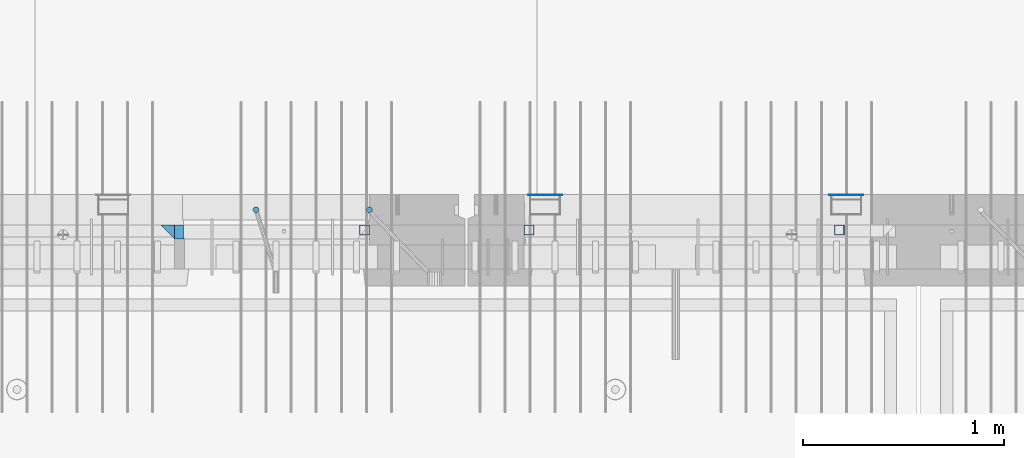
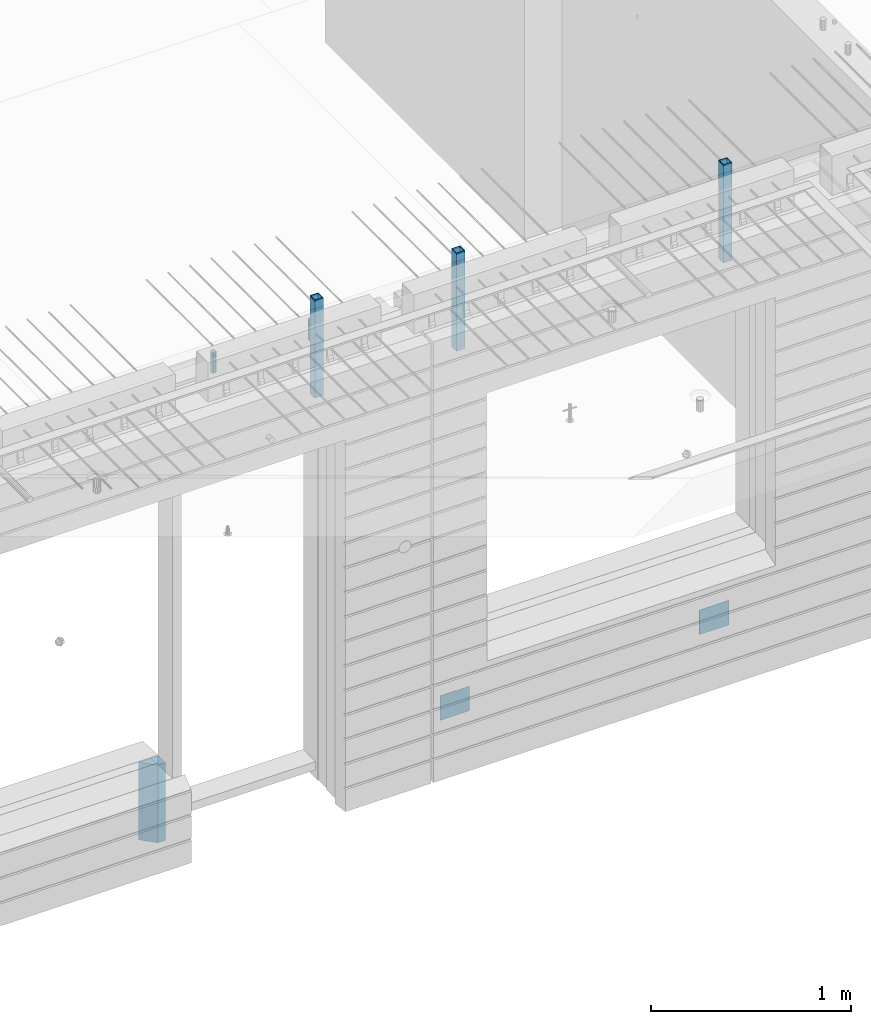
# One storey, part 17 of 350: 9 columns, 7 elements without a shape of their own.
"""IFC2X3 building model written with IfcOpenShell, lengths in millimetres."""

from ifc_helpers import new_model, si_unit, frame, origin_with_axes, place, context, subcontext, project, spatial, faceted_brep, material, type_object, element, aggregate, save


model = new_model("IFC2X3")

# Units and contexts
model_context = context("Model", 3, precision=1e-05, world=origin_with_axes())
body_context = subcontext(model_context, "Body", "Model", "MODEL_VIEW")
ifc_project = project(units=[si_unit("LENGTHUNIT", "METRE", prefix="MILLI"), si_unit("AREAUNIT", "SQUARE_METRE"), si_unit("VOLUMEUNIT", "CUBIC_METRE"), si_unit("MASSUNIT", "GRAM", prefix="KILO"), si_unit("TIMEUNIT", "SECOND"), si_unit("PLANEANGLEUNIT", "RADIAN"), si_unit("SOLIDANGLEUNIT", "STERADIAN"), si_unit("THERMODYNAMICTEMPERATUREUNIT", "DEGREE_CELSIUS"), si_unit("LUMINOUSINTENSITYUNIT", "LUMEN")], contexts=[model_context])

# Site, building, storey
site_placement = place(None, origin_with_axes())
site = spatial("IfcSite", under=ifc_project, at=site_placement, CompositionType="ELEMENT")
building_placement = place(site_placement, origin_with_axes())
building = spatial("IfcBuilding", under=site, at=building_placement, CompositionType="ELEMENT")
storey_placement = place(building_placement, origin_with_axes())
storey = spatial("IfcBuildingStorey", under=building, at=storey_placement, Name="2", CompositionType="ELEMENT", Elevation=0.0)

# Assembly, columns
assembly_1_placement = place(storey_placement, origin_with_axes())
assembly_1 = element("IfcElementAssembly", 1, at=assembly_1_placement, inside=storey, AssemblyPlace="NOTDEFINED", PredefinedType="REINFORCEMENT_UNIT")
ifc_material_1 = material(Name="CONCRETE/C35/45")
column_type_1 = type_object("IfcColumnType", PredefinedType="NOTDEFINED")
column_1_placement = place(assembly_1_placement, frame((24069.9998642727, 7815.0, 84755.0), z_axis=(1.0, 0.0, 0.0), x_axis=(0.0, 0.0, 1.0)))
column_1 = element("IfcColumn", 2, at=column_1_placement, type_object=column_type_1, material=ifc_material_1, Name="SK", context=body_context, shape_type="Brep", body=[
    faceted_brep([(0.0, -35.0, 35.0), (0.0, 35.0, 35.0), (0.0, -35.0, -35.0), (475.0, -35.0, 35.0), (475.0, -35.0, -35.0), (475.0, 35.0, 35.0)], [[[0, 1, 2]], [[3, 0, 2, 4]], [[3, 4, 5]], [[2, 1, 5, 4]], [[0, 3, 5, 1]]]),
])
column_type_2 = type_object("IfcColumnType", PredefinedType="NOTDEFINED")
column_2_placement = place(assembly_1_placement, frame((24129.9998642727, 7815.0, 84755.0), z_axis=(1.0, 0.0, 0.0), x_axis=(0.0, 0.0, 1.0)))
column_2 = element("IfcColumn", 3, at=column_2_placement, type_object=column_type_2, material=ifc_material_1, Name="SK", context=body_context, shape_type="Brep", body=[
    faceted_brep([(0.0, -35.0, -25.0), (0.0, 35.0, -25.0), (475.0, 35.0, -25.0), (475.0, -35.0, -25.0), (0.0, -35.0, 18.8457723764259), (0.0, 35.0, 20.640644171297), (475.0, 35.0, 20.640644171297), (475.0, -35.0, 18.8457723764259)], [[[0, 1, 2, 3]], [[1, 0, 4, 5]], [[2, 1, 5, 6]], [[3, 2, 6, 7]], [[0, 3, 7, 4]], [[6, 5, 4, 7]]]),
])
ifc_material_2 = material()
column_type_3 = type_object("IfcColumnType", Name="D30", PredefinedType="NOTDEFINED")
column_3_placement = place(assembly_1_placement, frame((24510.0000000048, 7924.99999999072, 87407.5), z_axis=(0.0, 1.0, 0.0), x_axis=(0.0, 0.0, 1.0)))
column_3 = element("IfcColumn", 4, at=column_3_placement, type_object=column_type_3, material=ifc_material_2, ObjectType="D30", context=body_context, shape_type="Brep", body=[
    faceted_brep([(0.0, -15.0, 0.0), (0.0, -12.9903810567666, -7.5), (125.0, -12.9903810567666, -7.5), (125.0, -15.0, 0.0), (0.0, -7.5, -12.9903810567666), (125.0, -7.5, -12.9903810567666), (0.0, 0.0, -15.0), (125.0, 0.0, -15.0), (0.0, 7.5, -12.9903810567666), (125.0, 7.5, -12.9903810567666), (0.0, 12.9903810567666, -7.5), (125.0, 12.9903810567666, -7.5), (0.0, 15.0, 0.0), (125.0, 15.0, 0.0), (0.0, 12.9903810567666, 7.5), (125.0, 12.9903810567666, 7.5), (0.0, 7.5, 12.9903810567666), (125.0, 7.5, 12.9903810567666), (0.0, 0.0, 15.0), (125.0, 0.0, 15.0), (0.0, -7.5, 12.9903810567666), (125.0, -7.5, 12.9903810567666), (0.0, -12.9903810567666, 7.5), (125.0, -12.9903810567666, 7.5)], [[[0, 1, 2, 3]], [[1, 4, 5, 2]], [[4, 6, 7, 5]], [[6, 8, 9, 7]], [[8, 10, 11, 9]], [[10, 12, 13, 11]], [[12, 14, 15, 13]], [[14, 16, 17, 15]], [[16, 18, 19, 17]], [[18, 20, 21, 19]], [[20, 22, 23, 21]], [[22, 0, 3, 23]], [[5, 7, 9, 11, 13, 15, 17, 19, 21, 23, 3, 2]], [[22, 20, 18, 16, 14, 12, 10, 8, 6, 4, 1, 0]]]),
])
column_4_placement = place(assembly_1_placement, frame((25074.9926665377, 7925.00000000707, 87407.5), z_axis=(0.0, 1.0, 0.0), x_axis=(0.0, 0.0, 1.0)))
column_4 = element("IfcColumn", 5, at=column_4_placement, type_object=column_type_3, material=ifc_material_2, ObjectType="D30", context=body_context, shape_type="Brep", body=[
    faceted_brep([(0.0, -15.0, 0.0), (0.0, -12.9903810567666, -7.5), (125.0, -12.9903810567666, -7.5), (125.0, -15.0, 0.0), (0.0, -7.5, -12.9903810567666), (125.0, -7.5, -12.9903810567666), (0.0, 0.0, -15.0), (125.0, 0.0, -15.0), (0.0, 7.5, -12.9903810567666), (125.0, 7.5, -12.9903810567666), (0.0, 12.9903810567666, -7.5), (125.0, 12.9903810567666, -7.5), (0.0, 15.0, 0.0), (125.0, 15.0, 0.0), (0.0, 12.9903810567666, 7.5), (125.0, 12.9903810567666, 7.5), (0.0, 7.5, 12.9903810567666), (125.0, 7.5, 12.9903810567666), (0.0, 0.0, 15.0), (125.0, 0.0, 15.0), (0.0, -7.5, 12.9903810567666), (125.0, -7.5, 12.9903810567666), (0.0, -12.9903810567666, 7.5), (125.0, -12.9903810567666, 7.5)], [[[0, 1, 2, 3]], [[1, 4, 5, 2]], [[4, 6, 7, 5]], [[6, 8, 9, 7]], [[8, 10, 11, 9]], [[10, 12, 13, 11]], [[12, 14, 15, 13]], [[14, 16, 17, 15]], [[16, 18, 19, 17]], [[18, 20, 21, 19]], [[20, 22, 23, 21]], [[22, 0, 3, 23]], [[5, 7, 9, 11, 13, 15, 17, 19, 21, 23, 3, 2]], [[22, 20, 18, 16, 14, 12, 10, 8, 6, 4, 1, 0]]]),
])

# Assemblies, columns
assembly_2_placement = place(storey_placement, origin_with_axes())
assembly_2 = element("IfcElementAssembly", 6, at=assembly_2_placement, inside=storey, AssemblyPlace="NOTDEFINED", PredefinedType="REINFORCEMENT_UNIT")
assembly_3_placement = place(assembly_2_placement, origin_with_axes())
assembly_3 = element("IfcElementAssembly", 7, at=assembly_3_placement, Name="Steel Assembly", AssemblyPlace="NOTDEFINED", PredefinedType="NOTDEFINED")
ifc_material_3 = material(Name="Undefined")
column_type_4 = type_object("IfcColumnType", PredefinedType="NOTDEFINED")
column_5_placement = place(assembly_3_placement, frame((25950.0, 7998.99999999844, 84754.9999999985), z_axis=(0.0, 1.0, 0.0), x_axis=(0.0, 0.0, 1.0)))
column_5 = element("IfcColumn", 8, at=column_5_placement, type_object=column_type_4, material=ifc_material_3, Name="SPK2", context=body_context, shape_type="Brep", body=[
    faceted_brep([(0.0, 85.0, -1.0), (0.0, 85.0, 1.0), (150.0, 85.0, 1.0), (150.0, 85.0, -1.0), (0.0, -85.0, 1.0), (150.0, -85.0, 1.0), (0.0, -85.0, -1.0), (150.0, -85.0, -1.0)], [[[0, 1, 2, 3]], [[1, 4, 5, 2]], [[4, 6, 7, 5]], [[6, 0, 3, 7]], [[5, 7, 3, 2]], [[6, 4, 1, 0]]]),
])
aggregate(assembly_3, [column_5])
assembly_4_placement = place(assembly_2_placement, origin_with_axes())
assembly_4 = element("IfcElementAssembly", 9, at=assembly_4_placement, Name="Steel Assembly", AssemblyPlace="NOTDEFINED", PredefinedType="NOTDEFINED")
column_6_placement = place(assembly_4_placement, frame((27450.0, 7998.99999999844, 84754.9999999985), z_axis=(0.0, 1.0, 0.0), x_axis=(0.0, 0.0, 1.0)))
column_6 = element("IfcColumn", 10, at=column_6_placement, type_object=column_type_4, material=ifc_material_3, Name="SPK2", context=body_context, shape_type="Brep", body=[
    faceted_brep([(0.0, 85.0, -1.0), (0.0, 85.0, 1.0), (150.0, 85.0, 1.0), (150.0, 85.0, -1.0), (0.0, -85.0, 1.0), (150.0, -85.0, 1.0), (0.0, -85.0, -1.0), (150.0, -85.0, -1.0)], [[[0, 1, 2, 3]], [[1, 4, 5, 2]], [[4, 6, 7, 5]], [[6, 0, 3, 7]], [[5, 7, 3, 2]], [[6, 4, 1, 0]]]),
])
aggregate(assembly_4, [column_6])
assembly_5_placement = place(assembly_2_placement, origin_with_axes())
assembly_5 = element("IfcElementAssembly", 11, at=assembly_5_placement, Name="Steel Assembly", AssemblyPlace="NOTDEFINED", PredefinedType="RIGID_FRAME")
ifc_material_4 = material(Name="STEEL/S355J2")
column_type_5 = type_object("IfcColumnType", Name="50X50X3", PredefinedType="NOTDEFINED")
column_7_placement = place(assembly_5_placement, frame((25870.0, 7825.0, 87140.0), z_axis=(-1.0, 3.00000001838171e-08, 0.0), x_axis=(0.0, 0.0, 1.0)))
column_7 = element("IfcColumn", 12, at=column_7_placement, type_object=column_type_5, material=ifc_material_4, ObjectType="50X50X3", context=body_context, shape_type="Brep", body=[
    faceted_brep([(0.0, 22.0, -22.0), (0.0, -22.0, -22.0), (600.0, -22.0, -22.0), (600.0, 22.0, -22.0), (0.0, -22.0, 22.0), (600.0, -22.0, 22.0), (0.0, 22.0, 22.0), (600.0, 22.0, 22.0), (0.0, 25.0, -25.0), (0.0, 25.0, 25.0), (600.0, 25.0, 25.0), (600.0, 25.0, -25.0), (0.0, -25.0, 25.0), (600.0, -25.0, 25.0), (0.0, -25.0, -25.0), (600.0, -25.0, -25.0)], [[[0, 1, 2, 3]], [[1, 4, 5, 2]], [[4, 6, 7, 5]], [[6, 0, 3, 7]], [[8, 9, 10, 11]], [[9, 12, 13, 10]], [[12, 14, 15, 13]], [[14, 8, 11, 15]], [[13, 15, 11, 10], [5, 7, 3, 2]], [[14, 12, 9, 8], [6, 4, 1, 0]]]),
])
aggregate(assembly_5, [column_7])

# Assembly
assembly_6_placement = place(assembly_1_placement, origin_with_axes())
assembly_6 = element("IfcElementAssembly", 13, at=assembly_6_placement, Name="Steel Assembly", AssemblyPlace="NOTDEFINED", PredefinedType="RIGID_FRAME")

aggregate(assembly_1, [assembly_6, column_3, column_4, column_1, column_2])

# Column
column_8_placement = place(assembly_6_placement, frame((25050.0, 7825.0, 87140.0), z_axis=(-1.0, 3.00000001838171e-08, 0.0), x_axis=(0.0, 0.0, 1.0)))
column_8 = element("IfcColumn", 14, at=column_8_placement, type_object=column_type_5, material=ifc_material_4, ObjectType="50X50X3", context=body_context, shape_type="Brep", body=[
    faceted_brep([(0.0, 22.0, -22.0), (0.0, -22.0, -22.0), (600.0, -22.0, -22.0), (600.0, 22.0, -22.0), (0.0, -22.0, 22.0), (600.0, -22.0, 22.0), (0.0, 22.0, 22.0), (600.0, 22.0, 22.0), (0.0, 25.0, -25.0), (0.0, 25.0, 25.0), (600.0, 25.0, 25.0), (600.0, 25.0, -25.0), (0.0, -25.0, 25.0), (600.0, -25.0, 25.0), (0.0, -25.0, -25.0), (600.0, -25.0, -25.0)], [[[0, 1, 2, 3]], [[1, 4, 5, 2]], [[4, 6, 7, 5]], [[6, 0, 3, 7]], [[8, 9, 10, 11]], [[9, 12, 13, 10]], [[12, 14, 15, 13]], [[14, 8, 11, 15]], [[13, 15, 11, 10], [5, 7, 3, 2]], [[14, 12, 9, 8], [6, 4, 1, 0]]]),
])

aggregate(assembly_6, [column_8])

# Assembly
assembly_7_placement = place(assembly_2_placement, origin_with_axes())
assembly_7 = element("IfcElementAssembly", 15, at=assembly_7_placement, Name="Steel Assembly", AssemblyPlace="NOTDEFINED", PredefinedType="RIGID_FRAME")

aggregate(assembly_2, [assembly_5, assembly_3, assembly_4, assembly_7])

# Column
column_9_placement = place(assembly_7_placement, frame((27415.0, 7825.0, 87140.0), z_axis=(-1.0, 3.00000001838171e-08, 0.0), x_axis=(0.0, 0.0, 1.0)))
column_9 = element("IfcColumn", 16, at=column_9_placement, type_object=column_type_5, material=ifc_material_4, ObjectType="50X50X3", context=body_context, shape_type="Brep", body=[
    faceted_brep([(0.0, 22.0, -22.0), (0.0, -22.0, -22.0), (600.0, -22.0, -22.0), (600.0, 22.0, -22.0), (0.0, -22.0, 22.0), (600.0, -22.0, 22.0), (0.0, 22.0, 22.0), (600.0, 22.0, 22.0), (0.0, 25.0, -25.0), (0.0, 25.0, 25.0), (600.0, 25.0, 25.0), (600.0, 25.0, -25.0), (0.0, -25.0, 25.0), (600.0, -25.0, 25.0), (0.0, -25.0, -25.0), (600.0, -25.0, -25.0)], [[[0, 1, 2, 3]], [[1, 4, 5, 2]], [[4, 6, 7, 5]], [[6, 0, 3, 7]], [[8, 9, 10, 11]], [[9, 12, 13, 10]], [[12, 14, 15, 13]], [[14, 8, 11, 15]], [[13, 15, 11, 10], [5, 7, 3, 2]], [[14, 12, 9, 8], [6, 4, 1, 0]]]),
])

aggregate(assembly_7, [column_9])

save(model, "model.ifc")
